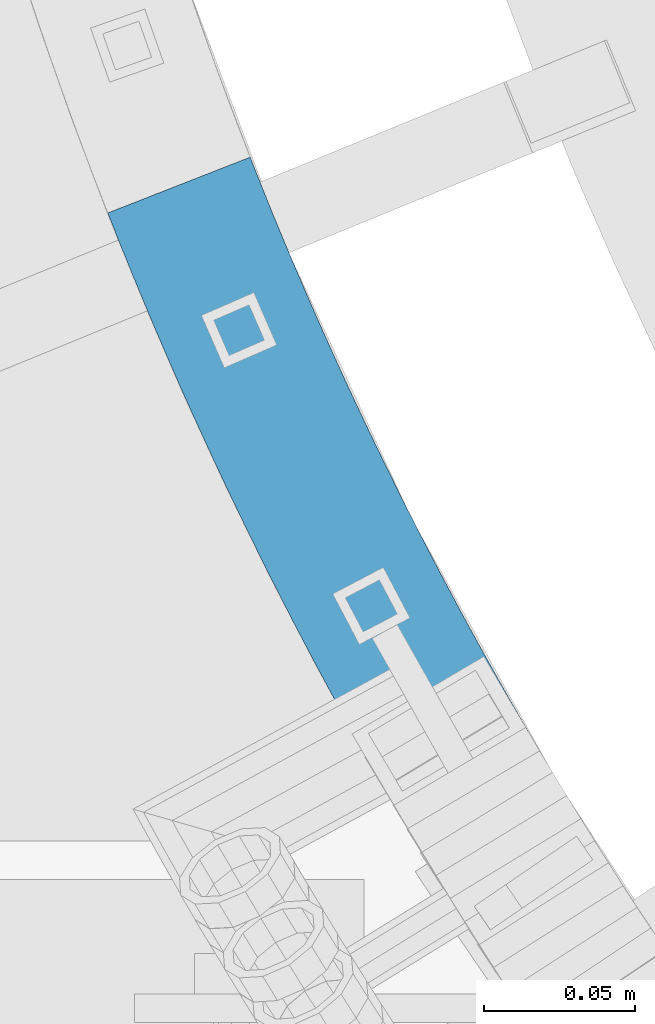
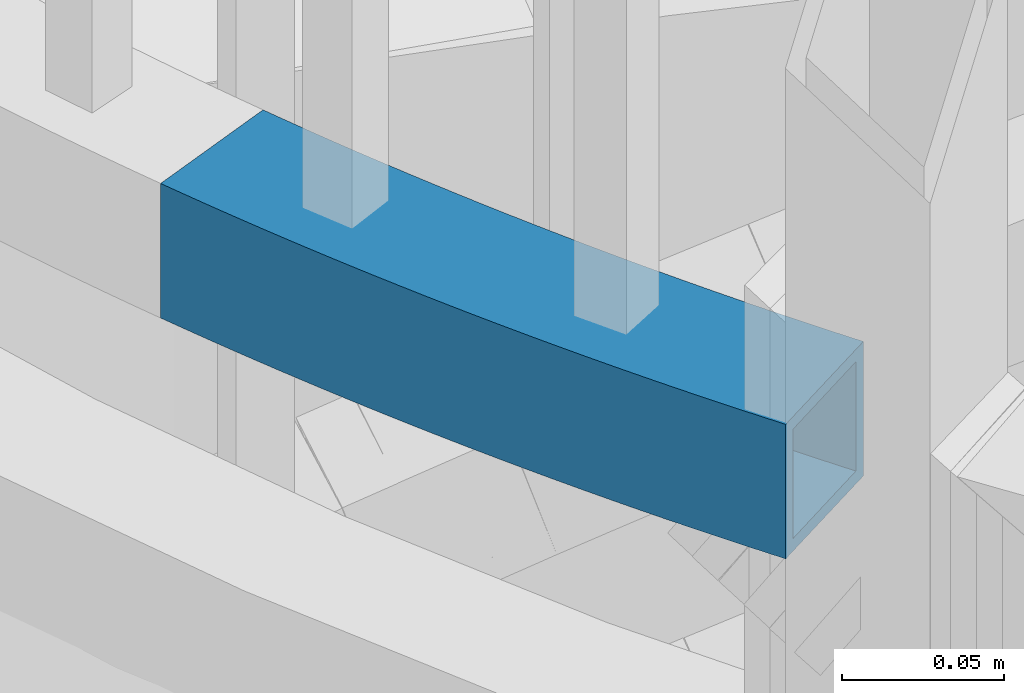
# One storey, part 473 of 975: 1 beam.
"""IFC2X3 building model written with IfcOpenShell, lengths in millimetres."""

from ifc_helpers import new_model, si_unit, frame, origin_with_axes, place, context, subcontext, project, spatial, faceted_brep, material, type_object, element, save


model = new_model("IFC2X3")

# Units and contexts
model_context = context("Model", 3, precision=1e-05, world=origin_with_axes())
body_context = subcontext(model_context, "Body", "Model", "MODEL_VIEW")
ifc_project = project(units=[si_unit("LENGTHUNIT", "METRE", prefix="MILLI"), si_unit("AREAUNIT", "SQUARE_METRE"), si_unit("VOLUMEUNIT", "CUBIC_METRE"), si_unit("MASSUNIT", "GRAM", prefix="KILO"), si_unit("TIMEUNIT", "SECOND"), si_unit("PLANEANGLEUNIT", "RADIAN"), si_unit("SOLIDANGLEUNIT", "STERADIAN"), si_unit("THERMODYNAMICTEMPERATUREUNIT", "DEGREE_CELSIUS"), si_unit("LUMINOUSINTENSITYUNIT", "LUMEN")], contexts=[model_context])

# Site, building, storey
site_placement = place(None, origin_with_axes())
site = spatial("IfcSite", under=ifc_project, at=site_placement, CompositionType="ELEMENT")
building_placement = place(site_placement, origin_with_axes())
building = spatial("IfcBuilding", under=site, at=building_placement, Name="Undefined", CompositionType="ELEMENT")
storey_placement = place(building_placement, origin_with_axes())
storey = spatial("IfcBuildingStorey", under=building, at=storey_placement, Name="Undefined", CompositionType="ELEMENT", Elevation=0.0)

# Beam
ifc_material = material()
beam_type = type_object("IfcBeamType", Name="HSS2X2X.188_TUBES", PredefinedType="NOTDEFINED")
beam_placement = place(storey_placement, frame((33547.4569280127, 2667.02838416945, 4254.5), z_axis=(0.0, 0.0, 1.0), x_axis=(-0.447935289860979, 0.894065979722504, 0.0)))
element("IfcBeam", 1, at=beam_placement, inside=storey, type_object=beam_type, material=ifc_material, Name="HANDRAIL", ObjectType="HSS2X2X.188_TUBES", context=body_context, shape_type="Brep", body=[
    faceted_brep([(23.9062195662409, 27.4404749350106, -25.3999999999996), (23.9062195662409, 27.4404749350106, 25.3999999999996), (28.2785710531207, 27.7508996670804, 25.3999999999996), (28.2785710531207, 27.7508996670804, -25.3999999999996), (32.6518584018995, 28.0478488278641, 25.3999999999996), (32.6518584018995, 28.0478488278641, -25.3999999999996), (37.0260400810184, 28.3313195973642, 25.3999999999996), (37.0260400810184, 28.3313195973642, -25.3999999999996), (41.4010745504183, 28.6013092835383, 25.3999999999996), (41.4010745504183, 28.6013092835383, -25.3999999999996), (45.7769202619493, 28.8578153224043, 25.3999999999996), (45.7769202619493, 28.8578153224043, -25.3999999999996), (50.1535356597506, 29.1008352780118, 25.3999999999996), (50.1535356597506, 29.1008352780118, -25.3999999999996), (54.5308791806547, 29.3303668424778, 25.3999999999996), (54.5308791806547, 29.3303668424778, -25.3999999999996), (58.9089092545819, 29.5464078360383, 25.3999999999996), (58.9089092545819, 29.5464078360383, -25.3999999999996), (63.287584304926, 29.748956207015, 25.3999999999996), (63.287584304926, 29.748956207015, -25.3999999999996), (67.6668627489616, 29.9380100318813, 25.3999999999996), (67.6668627489616, 29.9380100318813, -25.3999999999996), (72.0467029982283, 30.1135675152582, 25.3999999999996), (72.0467029982283, 30.1135675152582, -25.3999999999996), (76.4270634589393, 30.2756269899437, 25.3999999999996), (76.4270634589393, 30.2756269899437, -25.3999999999996), (80.8079025323568, 30.4241869169091, 25.3999999999996), (80.8079025323568, 30.4241869169091, -25.3999999999996), (85.1891786152064, 30.5592458853425, 25.3999999999996), (85.1891786152064, 30.5592458853425, -25.3999999999996), (89.5708501000554, 30.6808026126237, 25.3999999999996), (89.5708501000554, 30.6808026126237, -25.3999999999996), (93.9528753757222, 30.7888559443927, 25.3999999999996), (93.9528753757222, 30.7888559443927, -25.3999999999996), (98.3352128276638, 30.8834048544813, 25.3999999999996), (98.3352128276638, 30.8834048544813, -25.3999999999996), (102.717820838372, 30.9644484450073, 25.3999999999996), (102.717820838372, 30.9644484450073, -25.3999999999996), (107.100657787771, 31.0319859463198, 25.3999999999996), (107.100657787771, 31.0319859463198, -25.3999999999996), (111.483682053604, 31.0860167170431, 25.3999999999996), (111.483682053604, 31.0860167170431, -25.3999999999996), (115.866852011846, 31.1265402440658, 25.3999999999996), (115.866852011846, 31.1265402440658, -25.3999999999996), (120.250126037085, 31.1535561425553, 25.3999999999996), (120.250126037085, 31.1535561425553, -25.3999999999996), (124.633462502912, 31.1670641559431, 25.3999999999996), (124.633462502912, 31.1670641559431, -25.3999999999996), (129.016819782339, 31.1670641559576, 25.3999999999996), (129.016819782339, 31.1670641559576, -25.3999999999996), (133.400156248168, 31.1535561425808, 25.3999999999996), (133.400156248168, 31.1535561425808, -25.3999999999996), (137.783430273403, 31.1265402441131, 25.3999999999996), (137.783430273403, 31.1265402441131, -25.3999999999996), (142.166600231645, 31.0860167171049, 25.3999999999996), (142.166600231645, 31.0860167171049, -25.3999999999996), (146.549624497482, 31.0319859464034, 25.3999999999996), (146.549624497482, 31.0319859464034, -25.3999999999996), (150.932461446881, 30.9644484451055, 25.3999999999996), (150.932461446881, 30.9644484451055, -25.3999999999996), (155.315069457589, 30.8834048545978, 25.3999999999996), (155.315069457589, 30.8834048545978, -25.3999999999996), (159.69740690953, 30.7888559445273, 25.3999999999996), (159.69740690953, 30.7888559445273, -25.3999999999996), (164.079432185195, 30.6808026127837, 25.3999999999996), (164.079432185195, 30.6808026127837, -25.3999999999996), (168.461103670044, 30.5592458855135, 25.3999999999996), (168.461103670044, 30.5592458855135, -25.3999999999996), (172.842379752894, 30.4241869171019, 25.3999999999996), (172.842379752894, 30.4241869171019, -25.3999999999996), (177.223218826313, 30.2756269901547, 25.3999999999996), (177.223218826313, 30.2756269901547, -25.3999999999996), (181.603579287021, 30.1135675154837, 25.3999999999996), (181.603579287021, 30.1135675154837, -25.3999999999996), (185.983419536291, 29.938010032125, 25.3999999999996), (185.983419536291, 29.938010032125, -25.3999999999996), (190.362697980328, 29.7489562072806, 25.3999999999996), (190.362697980328, 29.7489562072806, -25.3999999999996), (194.741373030673, 29.546407836322, 25.3999999999996), (194.741373030673, 29.546407836322, -25.3999999999996), (199.119403104596, 29.330366842787, 25.3999999999996), (199.119403104596, 29.330366842787, -25.3999999999996), (203.4967466255, 29.1008352783319, 25.3999999999996), (203.4967466255, 29.1008352783319, -25.3999999999996), (207.8733620233, 28.8578153227427, 25.3999999999996), (207.8733620233, 28.8578153227427, -25.3999999999996), (212.249207734832, 28.6013092838984, 25.3999999999996), (212.249207734832, 28.6013092838984, -25.3999999999996), (216.624242204234, 28.3313195977425, 25.3999999999996), (216.624242204234, 28.3313195977425, -25.3999999999996), (220.998423883351, 28.047848828257, 25.3999999999996), (220.998423883351, 28.047848828257, -25.3999999999996), (225.371711232134, 27.7508996674915, 25.3999999999996), (225.371711232134, 27.7508996674915, -25.3999999999996), (229.744062719008, 27.4404749354362, 25.3999999999996), (229.744062719008, 27.4404749354362, -25.3999999999996), (234.115436821316, 27.1165775801164, 25.3999999999996), (234.115436821316, 27.1165775801164, -25.3999999999996), (238.485792025651, 26.7792106774468, 25.3999999999996), (238.485792025651, 26.7792106774468, -25.3999999999996), (242.855086828302, 26.4283774312898, 25.3999999999996), (242.855086828302, 26.4283774312898, -25.3999999999996), (247.223279735621, 26.0640811733865, 25.3999999999996), (247.223279735621, 26.0640811733865, -25.3999999999996), (251.590329264425, 25.6863253633237, 25.3999999999996), (251.590329264425, 25.6863253633237, -25.3999999999996), (247.134429688649, -24.9178736617832, 25.3999999999996), (247.134429688649, -24.9178736617832, -25.3999999999996), (251.344370628121, -25.2951135874791, -25.3999999999996), (251.344370628121, -25.2951135874791, 25.3999999999996), (242.923346214446, -24.5536091306494, 25.3999999999996), (242.923346214446, -24.5536091306494, -25.3999999999996), (238.711160196672, -24.2023234533845, 25.3999999999996), (238.711160196672, -24.2023234533845, -25.3999999999996), (234.497911636974, -23.8640199660222, 25.3999999999996), (234.497911636974, -23.8640199660222, -25.3999999999996), (230.283640547077, -23.5387018813053, 25.3999999999996), (230.283640547077, -23.5387018813053, -25.3999999999996), (226.068386948427, -23.2263722886673, 25.3999999999996), (226.068386948427, -23.2263722886673, -25.3999999999996), (221.852190871796, -22.927034154196, 25.3999999999996), (221.852190871796, -22.927034154196, -25.3999999999996), (217.635092356897, -22.6406903205971, 25.3999999999996), (217.635092356897, -22.6406903205971, -25.3999999999996), (213.417131452035, -22.3673435071651, 25.3999999999996), (213.417131452035, -22.3673435071651, -25.3999999999996), (209.198348213684, -22.1069963098016, 25.3999999999996), (209.198348213684, -22.1069963098016, -25.3999999999996), (204.978782706135, -21.8596512009135, 25.3999999999996), (204.978782706135, -21.8596512009135, -25.3999999999996), (200.758475001116, -21.6253105294527, 25.3999999999996), (200.758475001116, -21.6253105294527, -25.3999999999996), (196.537465177385, -21.4039765208763, 25.3999999999996), (196.537465177385, -21.4039765208763, -25.3999999999996), (192.315793320387, -21.195651277103, 25.3999999999996), (192.315793320387, -21.195651277103, -25.3999999999996), (188.093499521841, -21.0003367765385, 25.3999999999996), (188.093499521841, -21.0003367765385, -25.3999999999996), (183.870623879375, -20.8180348740061, 25.3999999999996), (183.870623879375, -20.8180348740061, -25.3999999999996), (179.647206496153, -20.6487473007692, 25.3999999999996), (179.647206496153, -20.6487473007692, -25.3999999999996), (175.423287480466, -20.4924756644832, 25.3999999999996), (175.423287480466, -20.4924756644832, -25.3999999999996), (171.198906945387, -20.3492214492107, 25.3999999999996), (171.198906945387, -20.3492214492107, -25.3999999999996), (166.974105008354, -20.2189860153849, 25.3999999999996), (166.974105008354, -20.2189860153849, -25.3999999999996), (162.748921790821, -20.1017705998056, 25.3999999999996), (162.748921790821, -20.1017705998056, -25.3999999999996), (158.523397417857, -19.9975763156217, 25.3999999999996), (158.523397417857, -19.9975763156217, -25.3999999999996), (154.297572017769, -19.9064041523379, 25.3999999999996), (154.297572017769, -19.9064041523379, -25.3999999999996), (150.071485721728, -19.828254975786, 25.3999999999996), (150.071485721728, -19.828254975786, -25.3999999999996), (145.845178663381, -19.7631295281026, 25.3999999999996), (145.845178663381, -19.7631295281026, -25.3999999999996), (141.61869097847, -19.7110284277733, 25.3999999999996), (141.61869097847, -19.7110284277733, -25.3999999999996), (137.392062804451, -19.6719521695886, 25.3999999999996), (137.392062804451, -19.6719521695886, -25.3999999999996), (133.165334280113, -19.6459011246407, 25.3999999999996), (133.165334280113, -19.6459011246407, -25.3999999999996), (128.938545545208, -19.6328755403156, 25.3999999999996), (128.938545545208, -19.6328755403156, -25.3999999999996), (124.71173674005, -19.6328755403265, 25.3999999999996), (124.71173674005, -19.6328755403265, -25.3999999999996), (120.484948005142, -19.6459011246661, 25.3999999999996), (120.484948005142, -19.6459011246661, -25.3999999999996), (116.258219480806, -19.6719521696396, 25.3999999999996), (116.258219480806, -19.6719521696396, -25.3999999999996), (112.031591306786, -19.7110284278424, 25.3999999999996), (112.031591306786, -19.7110284278424, -25.3999999999996), (107.805103621871, -19.7631295281826, 25.3999999999996), (107.805103621871, -19.7631295281826, -25.3999999999996), (103.578796563525, -19.8282549758769, 25.3999999999996), (103.578796563525, -19.8282549758769, -25.3999999999996), (99.3527102674871, -19.9064041524507, 25.3999999999996), (99.3527102674871, -19.9064041524507, -25.3999999999996), (95.1268848674008, -19.9975763157527, 25.3999999999996), (95.1268848674008, -19.9975763157527, -25.3999999999996), (90.9013604944339, -20.1017705999548, 25.3999999999996), (90.9013604944339, -20.1017705999548, -25.3999999999996), (86.6761772769023, -20.2189860155486, 25.3999999999996), (86.6761772769023, -20.2189860155486, -25.3999999999996), (82.4513753398696, -20.3492214493963, 25.3999999999996), (82.4513753398696, -20.3492214493963, -25.3999999999996), (78.226994804787, -20.4924756646906, 25.3999999999996), (78.226994804787, -20.4924756646906, -25.3999999999996), (74.0030757891036, -20.6487473009911, 25.3999999999996), (74.0030757891036, -20.6487473009911, -25.3999999999996), (69.7796584058797, -20.8180348742462, 25.3999999999996), (69.7796584058797, -20.8180348742462, -25.3999999999996), (65.556782763415, -21.0003367767968, 25.3999999999996), (65.556782763415, -21.0003367767968, -25.3999999999996), (61.3344889648706, -21.1956512773759, 25.3999999999996), (61.3344889648706, -21.1956512773759, -25.3999999999996), (57.1128171078708, -21.4039765211674, 25.3999999999996), (57.1128171078708, -21.4039765211674, -25.3999999999996), (52.8918072841407, -21.6253105297619, 25.3999999999996), (52.8918072841407, -21.6253105297619, -25.3999999999996), (48.6714995791208, -21.8596512012336, 25.3999999999996), (48.6714995791208, -21.8596512012336, -25.3999999999996), (44.4519340715724, -22.1069963101436, 25.3999999999996), (44.4519340715724, -22.1069963101436, -25.3999999999996), (40.2331508332209, -22.3673435075289, 25.3999999999996), (40.2331508332209, -22.3673435075289, -25.3999999999996), (36.0151899283574, -22.6406903209718, 25.3999999999996), (36.0151899283574, -22.6406903209718, -25.3999999999996), (31.7980914134623, -22.9270341545925, 25.3999999999996), (31.7980914134623, -22.9270341545925, -25.3999999999996), (27.5818953368289, -23.2263722890821, 25.3999999999996), (27.5818953368289, -23.2263722890821, -25.3999999999996), (255.956193942395, 25.2951135885232, -25.3999999999996), (23.0098913682887, 27.3740614169692, -25.3999999999996), (23.0098913682887, 27.3740614169692, 25.3999999999996), (255.956193942395, 25.2951135885232, 25.3999999999996), (24.2508141697344, 22.6904580077571, 20.6374999999998), (24.2508141697344, 22.6904580077571, -20.6374999999998), (28.6085260869022, 22.9998433712935, -20.6374999999998), (28.6085260869022, 22.9998433712935, 20.6374999999998), (32.9671707325051, 23.2957982826629, -20.6374999999998), (32.9671707325051, 23.2957982826629, 20.6374999999998), (37.3267067140368, 23.5783199312827, -20.6374999999998), (37.3267067140368, 23.5783199312827, 20.6374999999998), (41.6870926305273, 23.8474056341292, -20.6374999999998), (41.6870926305273, 23.8474056341292, 20.6374999999998), (46.0482870729338, 24.1030528358169, -20.6374999999998), (46.0482870729338, 24.1030528358169, 20.6374999999998), (50.4102486245374, 24.3452591085334, -20.6374999999998), (50.4102486245374, 24.3452591085334, 20.6374999999998), (54.7729358613324, 24.5740221521446, -20.6374999999998), (54.7729358613324, 24.5740221521446, 20.6374999999998), (59.136307352419, 24.7893397941552, -20.6374999999998), (59.136307352419, 24.7893397941552, 20.6374999999998), (63.5003216604091, 24.9912099897847, -20.6374999999998), (63.5003216604091, 24.9912099897847, 20.6374999999998), (67.8649373417975, 25.1796308219346, -20.6374999999998), (67.8649373417975, 25.1796308219346, 20.6374999999998), (72.2301129473726, 25.3546005012358, -20.6374999999998), (72.2301129473726, 25.3546005012358, 20.6374999999998), (76.5958070226116, 25.5161173660672, -20.6374999999998), (76.5958070226116, 25.5161173660672, 20.6374999999998), (80.9619781080637, 25.6641798825694, -20.6374999999998), (80.9619781080637, 25.6641798825694, 20.6374999999998), (85.3285847397401, 25.798786644631, -20.6374999999998), (85.3285847397401, 25.798786644631, 20.6374999999998), (89.6955854495282, 25.9199363739499, -20.6374999999998), (89.6955854495282, 25.9199363739499, 20.6374999999998), (94.0629387655663, 26.0276279200007, -20.6374999999998), (94.0629387655663, 26.0276279200007, 20.6374999999998), (98.4306032126442, 26.1218602600784, -20.6374999999998), (98.4306032126442, 26.1218602600784, 20.6374999999998), (102.798537312605, 26.2026324992985, -20.6374999999998), (102.798537312605, 26.2026324992985, 20.6374999999998), (107.166699584717, 26.2699438705858, -20.6374999999998), (107.166699584717, 26.2699438705858, 20.6374999999998), (111.535048546089, 26.3237937347112, -20.6374999999998), (111.535048546089, 26.3237937347112, 20.6374999999998), (115.903542712063, 26.3641815802839, -20.6374999999998), (115.903542712063, 26.3641815802839, 20.6374999999998), (120.272140596593, 26.3911070237555, -20.6374999999998), (120.272140596593, 26.3911070237555, 20.6374999999998), (124.640800712645, 26.4045698094196, -20.6374999999998), (124.640800712645, 26.4045698094196, 20.6374999999998), (129.009481572604, 26.4045698094269, -20.6374999999998), (129.009481572604, 26.4045698094269, 20.6374999999998), (133.378141688663, 26.3911070237846, -20.6374999999998), (133.378141688663, 26.3911070237846, 20.6374999999998), (137.746739573187, 26.3641815803276, -20.6374999999998), (137.746739573187, 26.3641815803276, 20.6374999999998), (142.115233739161, 26.3237937347731, -20.6374999999998), (142.115233739161, 26.3237937347731, 20.6374999999998), (146.483582700535, 26.2699438706695, -20.6374999999998), (146.483582700535, 26.2699438706695, 20.6374999999998), (150.851744972646, 26.2026324993967, -20.6374999999998), (150.851744972646, 26.2026324993967, 20.6374999999998), (155.219679072605, 26.1218602602021, -20.6374999999998), (155.219679072605, 26.1218602602021, 20.6374999999998), (159.587343519683, 26.0276279201316, -20.6374999999998), (159.587343519683, 26.0276279201316, 20.6374999999998), (163.954696835724, 25.9199363741027, -20.6374999999998), (163.954696835724, 25.9199363741027, 20.6374999999998), (168.321697545513, 25.798786644802, -20.6374999999998), (168.321697545513, 25.798786644802, 20.6374999999998), (172.688304177189, 25.6641798827586, -20.6374999999998), (172.688304177189, 25.6641798827586, 20.6374999999998), (177.054475262637, 25.5161173662782, -20.6374999999998), (177.054475262637, 25.5161173662782, 20.6374999999998), (181.420169337878, 25.3546005014614, -20.6374999999998), (181.420169337878, 25.3546005014614, 20.6374999999998), (185.785344943455, 25.1796308221747, -20.6374999999998), (185.785344943455, 25.1796308221747, 20.6374999999998), (190.149960624845, 24.9912099900466, -20.6374999999998), (190.149960624845, 24.9912099900466, 20.6374999999998), (194.513974932832, 24.7893397944354, -20.6374999999998), (194.513974932832, 24.7893397944354, 20.6374999999998), (198.877346423922, 24.5740221524429, -20.6374999999998), (198.877346423922, 24.5740221524429, 20.6374999999998), (203.240033660715, 24.3452591088535, -20.6374999999998), (203.240033660715, 24.3452591088535, 20.6374999999998), (207.601995212317, 24.1030528361553, -20.6374999999998), (207.601995212317, 24.1030528361553, 20.6374999999998), (211.963189654723, 23.8474056344858, -20.6374999999998), (211.963189654723, 23.8474056344858, 20.6374999999998), (216.323575571212, 23.5783199316502, -20.6374999999998), (216.323575571212, 23.5783199316502, 20.6374999999998), (220.683111552746, 23.2957982830558, -20.6374999999998), (220.683111552746, 23.2957982830558, 20.6374999999998), (225.04175619835, 22.9998433717083, -20.6374999999998), (225.04175619835, 22.9998433717083, 20.6374999999998), (229.399468115516, 22.6904580081791, -20.6374999999998), (229.399468115516, 22.6904580081791, 20.6374999999998), (233.756205920603, 22.3676451306019, -20.6374999999998), (233.756205920603, 22.3676451306019, 20.6374999999998), (238.11192823921, 22.0314078046213, -20.6374999999998), (238.11192823921, 22.0314078046213, 20.6374999999998), (242.466593706587, 21.6817492233531, -20.6374999999998), (242.466593706587, 21.6817492233531, 20.6374999999998), (246.820160968009, 21.3186727073808, -20.6374999999998), (246.820160968009, 21.3186727073808, 20.6374999999998), (251.172588679197, 20.942181704726, -20.6374999999998), (251.172588679197, 20.942181704726, 20.6374999999998), (255.523835506681, 20.5522797907688, -20.6374999999998), (255.523835506681, 20.5522797907688, 20.6374999999998), (251.776729063833, -20.552279789732, 20.6374999999998), (251.776729063833, -20.552279789732, -20.6374999999998), (247.552170273881, -20.1737300031782, -20.6374999999998), (247.552170273881, -20.1737300031782, 20.6374999999998), (243.326464982052, -19.8082006646509, -20.6374999999998), (243.326464982052, -19.8082006646509, 20.6374999999998), (239.099653318386, -19.4556952454477, -20.6374999999998), (239.099653318386, -19.4556952454477, 20.6374999999998), (234.871775423409, -19.1162170932002, -20.6374999999998), (234.871775423409, -19.1162170932002, 20.6374999999998), (230.642871447788, -18.7897694317944, -20.6374999999998), (230.642871447788, -18.7897694317944, 20.6374999999998), (226.412981551919, -18.4763553614102, -20.6374999999998), (226.412981551919, -18.4763553614102, 20.6374999999998), (222.182145905574, -18.1759778584164, -20.6374999999998), (222.182145905574, -18.1759778584164, 20.6374999999998), (217.950404687504, -17.8886397753849, -20.6374999999998), (217.950404687504, -17.8886397753849, 20.6374999999998), (213.717798085054, -17.6143438410836, -20.6374999999998), (213.717798085054, -17.6143438410836, 20.6374999999998), (209.484366293791, -17.3530926603926, -20.6374999999998), (209.484366293791, -17.3530926603926, 20.6374999999998), (205.25014951712, -17.1048887143224, -20.6374999999998), (205.25014951712, -17.1048887143224, 20.6374999999998), (201.015187965899, -16.8697343599742, -20.6374999999998), (201.015187965899, -16.8697343599742, 20.6374999999998), (196.77952185806, -16.6476318305322, -20.6374999999998), (196.77952185806, -16.6476318305322, 20.6374999999998), (192.543191418225, -16.4385832352273, -20.6374999999998), (192.543191418225, -16.4385832352273, 20.6374999999998), (188.306236877324, -16.2425905593045, -20.6374999999998), (188.306236877324, -16.2425905593045, 20.6374999999998), (184.068698472214, -16.0596556640558, -20.6374999999998), (184.068698472214, -16.0596556640558, 20.6374999999998), (179.830616445295, -15.8897802867468, -20.6374999999998), (179.830616445295, -15.8897802867468, 20.6374999999998), (175.592031044143, -15.7329660406103, -20.6374999999998), (175.592031044143, -15.7329660406103, 20.6374999999998), (171.35298252109, -15.5892144148675, -20.6374999999998), (171.35298252109, -15.5892144148675, 20.6374999999998), (167.113511132889, -15.4585267746734, -20.6374999999998), (167.113511132889, -15.4585267746734, 20.6374999999998), (162.873657140293, -15.3409043611246, -20.6374999999998), (162.873657140293, -15.3409043611246, 20.6374999999998), (158.633460807701, -15.2363482912369, -20.6374999999998), (158.633460807701, -15.2363482912369, 20.6374999999998), (154.392962402751, -15.1448595579386, -20.6374999999998), (154.392962402751, -15.1448595579386, 20.6374999999998), (150.152202195963, -15.0664390300735, -20.6374999999998), (150.152202195963, -15.0664390300735, 20.6374999999998), (145.91122046033, -15.001087452365, -20.6374999999998), (145.91122046033, -15.001087452365, 20.6374999999998), (141.670057470958, -14.9488054454414, -20.6374999999998), (141.670057470958, -14.9488054454414, 20.6374999999998), (137.428753504664, -14.9095935058067, -20.6374999999998), (137.428753504664, -14.9095935058067, 20.6374999999998), (133.18734883962, -14.8834520058335, -20.6374999999998), (133.18734883962, -14.8834520058335, 20.6374999999998), (128.945883754939, -14.8703811937921, -20.6374999999998), (128.945883754939, -14.8703811937921, 20.6374999999998), (124.704398530317, -14.8703811937994, -20.6374999999998), (124.704398530317, -14.8703811937994, 20.6374999999998), (120.462933445637, -14.8834520058626, -20.6374999999998), (120.462933445637, -14.8834520058626, 20.6374999999998), (116.22152878059, -14.9095935058504, -20.6374999999998), (116.22152878059, -14.9095935058504, 20.6374999999998), (111.980224814301, -14.9488054455069, -20.6374999999998), (111.980224814301, -14.9488054455069, 20.6374999999998), (107.739061824928, -15.0010874524414, -20.6374999999998), (107.739061824928, -15.0010874524414, 20.6374999999998), (103.498080089292, -15.0664390301681, -20.6374999999998), (103.498080089292, -15.0664390301681, 20.6374999999998), (99.2573198825012, -15.144859558055, -20.6374999999998), (99.2573198825012, -15.144859558055, 20.6374999999998), (95.0168214775549, -15.2363482913715, -20.6374999999998), (95.0168214775549, -15.2363482913715, 20.6374999999998), (90.776625144963, -15.3409043612701, -20.6374999999998), (90.776625144963, -15.3409043612701, 20.6374999999998), (86.5367711523668, -15.4585267748444, -20.6374999999998), (86.5367711523668, -15.4585267748444, 20.6374999999998), (82.2972997641664, -15.5892144150494, -20.6374999999998), (82.2972997641664, -15.5892144150494, 20.6374999999998), (78.0582512411129, -15.7329660408141, -20.6374999999998), (78.0582512411129, -15.7329660408141, 20.6374999999998), (73.8196658399575, -15.8897802869687, -20.6374999999998), (73.8196658399575, -15.8897802869687, 20.6374999999998), (69.5815838130438, -16.0596556642959, -20.6374999999998), (69.5815838130438, -16.0596556642959, 20.6374999999998), (65.3440454079318, -16.2425905595628, -20.6374999999998), (65.3440454079318, -16.2425905595628, 20.6374999999998), (61.1070908670299, -16.4385832355001, -20.6374999999998), (61.1070908670299, -16.4385832355001, 20.6374999999998), (56.8707604271949, -16.6476318308196, -20.6374999999998), (56.8707604271949, -16.6476318308196, 20.6374999999998), (52.6350943193556, -16.8697343602798, -20.6374999999998), (52.6350943193556, -16.8697343602798, 20.6374999999998), (48.4001327681362, -17.1048887146426, -20.6374999999998), (48.4001327681362, -17.1048887146426, 20.6374999999998), (44.1659159914634, -17.3530926607345, -20.6374999999998), (44.1659159914634, -17.3530926607345, 20.6374999999998), (39.9324842002006, -17.6143438414474, -20.6374999999998), (39.9324842002006, -17.6143438414474, 20.6374999999998), (35.6998775977518, -17.8886397757669, -20.6374999999998), (35.6998775977518, -17.8886397757669, 20.6374999999998), (31.4681363796808, -18.1759778588093, -20.6374999999998), (31.4681363796808, -18.1759778588093, 20.6374999999998), (27.2373007333354, -18.4763553618213, 20.6374999999998), (23.4423115260724, 22.6305519320158, 20.6374999999998), (23.4423115260724, 22.6305519320158, -20.6374999999998), (27.2373007333354, -18.4763553618213, -20.6374999999998)], [[[0, 1, 2, 3]], [[3, 2, 4, 5]], [[5, 4, 6, 7]], [[7, 6, 8, 9]], [[9, 8, 10, 11]], [[11, 10, 12, 13]], [[13, 12, 14, 15]], [[15, 14, 16, 17]], [[17, 16, 18, 19]], [[19, 18, 20, 21]], [[21, 20, 22, 23]], [[23, 22, 24, 25]], [[25, 24, 26, 27]], [[27, 26, 28, 29]], [[29, 28, 30, 31]], [[31, 30, 32, 33]], [[33, 32, 34, 35]], [[35, 34, 36, 37]], [[37, 36, 38, 39]], [[39, 38, 40, 41]], [[41, 40, 42, 43]], [[43, 42, 44, 45]], [[45, 44, 46, 47]], [[47, 46, 48, 49]], [[49, 48, 50, 51]], [[51, 50, 52, 53]], [[53, 52, 54, 55]], [[55, 54, 56, 57]], [[57, 56, 58, 59]], [[59, 58, 60, 61]], [[61, 60, 62, 63]], [[63, 62, 64, 65]], [[65, 64, 66, 67]], [[67, 66, 68, 69]], [[69, 68, 70, 71]], [[71, 70, 72, 73]], [[73, 72, 74, 75]], [[75, 74, 76, 77]], [[77, 76, 78, 79]], [[79, 78, 80, 81]], [[81, 80, 82, 83]], [[83, 82, 84, 85]], [[85, 84, 86, 87]], [[87, 86, 88, 89]], [[89, 88, 90, 91]], [[91, 90, 92, 93]], [[93, 92, 94, 95]], [[95, 94, 96, 97]], [[97, 96, 98, 99]], [[99, 98, 100, 101]], [[101, 100, 102, 103]], [[103, 102, 104, 105]], [[106, 107, 108, 109]], [[110, 111, 107, 106]], [[112, 113, 111, 110]], [[114, 115, 113, 112]], [[116, 117, 115, 114]], [[118, 119, 117, 116]], [[120, 121, 119, 118]], [[122, 123, 121, 120]], [[124, 125, 123, 122]], [[126, 127, 125, 124]], [[128, 129, 127, 126]], [[130, 131, 129, 128]], [[132, 133, 131, 130]], [[134, 135, 133, 132]], [[136, 137, 135, 134]], [[138, 139, 137, 136]], [[140, 141, 139, 138]], [[142, 143, 141, 140]], [[144, 145, 143, 142]], [[146, 147, 145, 144]], [[148, 149, 147, 146]], [[150, 151, 149, 148]], [[152, 153, 151, 150]], [[154, 155, 153, 152]], [[156, 157, 155, 154]], [[158, 159, 157, 156]], [[160, 161, 159, 158]], [[162, 163, 161, 160]], [[164, 165, 163, 162]], [[166, 167, 165, 164]], [[168, 169, 167, 166]], [[170, 171, 169, 168]], [[172, 173, 171, 170]], [[174, 175, 173, 172]], [[176, 177, 175, 174]], [[178, 179, 177, 176]], [[180, 181, 179, 178]], [[182, 183, 181, 180]], [[184, 185, 183, 182]], [[186, 187, 185, 184]], [[188, 189, 187, 186]], [[190, 191, 189, 188]], [[192, 193, 191, 190]], [[194, 195, 193, 192]], [[196, 197, 195, 194]], [[198, 199, 197, 196]], [[200, 201, 199, 198]], [[202, 203, 201, 200]], [[204, 205, 203, 202]], [[206, 207, 205, 204]], [[208, 209, 207, 206]], [[210, 211, 209, 208]], [[211, 210, 212, 213]], [[0, 3, 5, 7, 9, 11, 13, 15, 17, 19, 21, 23, 25, 27, 29, 31, 33, 35, 37, 39, 41, 43, 45, 47, 49, 51, 53, 55, 57, 59, 61, 63, 65, 67, 69, 71, 73, 75, 77, 79, 81, 83, 85, 87, 89, 91, 93, 95, 97, 99, 101, 103, 105, 214, 108, 107, 111, 113, 115, 117, 119, 121, 123, 125, 127, 129, 131, 133, 135, 137, 139, 141, 143, 145, 147, 149, 151, 153, 155, 157, 159, 161, 163, 165, 167, 169, 171, 173, 175, 177, 179, 181, 183, 185, 187, 189, 191, 193, 195, 197, 199, 201, 203, 205, 207, 209, 211, 213, 215]], [[1, 0, 215, 216]], [[210, 208, 206, 204, 202, 200, 198, 196, 194, 192, 190, 188, 186, 184, 182, 180, 178, 176, 174, 172, 170, 168, 166, 164, 162, 160, 158, 156, 154, 152, 150, 148, 146, 144, 142, 140, 138, 136, 134, 132, 130, 128, 126, 124, 122, 120, 118, 116, 114, 112, 110, 106, 109, 217, 104, 102, 100, 98, 96, 94, 92, 90, 88, 86, 84, 82, 80, 78, 76, 74, 72, 70, 68, 66, 64, 62, 60, 58, 56, 54, 52, 50, 48, 46, 44, 42, 40, 38, 36, 34, 32, 30, 28, 26, 24, 22, 20, 18, 16, 14, 12, 10, 8, 6, 4, 2, 1, 216, 212]], [[105, 104, 217, 214]], [[218, 219, 220, 221]], [[221, 220, 222, 223]], [[223, 222, 224, 225]], [[225, 224, 226, 227]], [[227, 226, 228, 229]], [[229, 228, 230, 231]], [[231, 230, 232, 233]], [[233, 232, 234, 235]], [[235, 234, 236, 237]], [[237, 236, 238, 239]], [[239, 238, 240, 241]], [[241, 240, 242, 243]], [[243, 242, 244, 245]], [[245, 244, 246, 247]], [[247, 246, 248, 249]], [[249, 248, 250, 251]], [[251, 250, 252, 253]], [[253, 252, 254, 255]], [[255, 254, 256, 257]], [[257, 256, 258, 259]], [[259, 258, 260, 261]], [[261, 260, 262, 263]], [[263, 262, 264, 265]], [[265, 264, 266, 267]], [[267, 266, 268, 269]], [[269, 268, 270, 271]], [[271, 270, 272, 273]], [[273, 272, 274, 275]], [[275, 274, 276, 277]], [[277, 276, 278, 279]], [[279, 278, 280, 281]], [[281, 280, 282, 283]], [[283, 282, 284, 285]], [[285, 284, 286, 287]], [[287, 286, 288, 289]], [[289, 288, 290, 291]], [[291, 290, 292, 293]], [[293, 292, 294, 295]], [[295, 294, 296, 297]], [[297, 296, 298, 299]], [[299, 298, 300, 301]], [[301, 300, 302, 303]], [[303, 302, 304, 305]], [[305, 304, 306, 307]], [[307, 306, 308, 309]], [[309, 308, 310, 311]], [[311, 310, 312, 313]], [[313, 312, 314, 315]], [[315, 314, 316, 317]], [[317, 316, 318, 319]], [[319, 318, 320, 321]], [[321, 320, 322, 323]], [[323, 322, 324, 325]], [[109, 108, 214, 217], [326, 325, 324, 327]], [[328, 329, 326, 327]], [[330, 331, 329, 328]], [[332, 333, 331, 330]], [[334, 335, 333, 332]], [[336, 337, 335, 334]], [[338, 339, 337, 336]], [[340, 341, 339, 338]], [[342, 343, 341, 340]], [[344, 345, 343, 342]], [[346, 347, 345, 344]], [[348, 349, 347, 346]], [[350, 351, 349, 348]], [[352, 353, 351, 350]], [[354, 355, 353, 352]], [[356, 357, 355, 354]], [[358, 359, 357, 356]], [[360, 361, 359, 358]], [[362, 363, 361, 360]], [[364, 365, 363, 362]], [[366, 367, 365, 364]], [[368, 369, 367, 366]], [[370, 371, 369, 368]], [[372, 373, 371, 370]], [[374, 375, 373, 372]], [[376, 377, 375, 374]], [[378, 379, 377, 376]], [[380, 381, 379, 378]], [[382, 383, 381, 380]], [[384, 385, 383, 382]], [[386, 387, 385, 384]], [[388, 389, 387, 386]], [[390, 391, 389, 388]], [[392, 393, 391, 390]], [[394, 395, 393, 392]], [[396, 397, 395, 394]], [[398, 399, 397, 396]], [[400, 401, 399, 398]], [[402, 403, 401, 400]], [[404, 405, 403, 402]], [[406, 407, 405, 404]], [[408, 409, 407, 406]], [[410, 411, 409, 408]], [[412, 413, 411, 410]], [[414, 415, 413, 412]], [[416, 417, 415, 414]], [[418, 419, 417, 416]], [[420, 421, 419, 418]], [[422, 423, 421, 420]], [[424, 425, 423, 422]], [[426, 427, 425, 424]], [[428, 429, 427, 426]], [[430, 431, 429, 428]], [[218, 221, 223, 225, 227, 229, 231, 233, 235, 237, 239, 241, 243, 245, 247, 249, 251, 253, 255, 257, 259, 261, 263, 265, 267, 269, 271, 273, 275, 277, 279, 281, 283, 285, 287, 289, 291, 293, 295, 297, 299, 301, 303, 305, 307, 309, 311, 313, 315, 317, 319, 321, 323, 325, 326, 329, 331, 333, 335, 337, 339, 341, 343, 345, 347, 349, 351, 353, 355, 357, 359, 361, 363, 365, 367, 369, 371, 373, 375, 377, 379, 381, 383, 385, 387, 389, 391, 393, 395, 397, 399, 401, 403, 405, 407, 409, 411, 413, 415, 417, 419, 421, 423, 425, 427, 429, 431, 432, 433]], [[219, 218, 433, 434]], [[430, 428, 426, 424, 422, 420, 418, 416, 414, 412, 410, 408, 406, 404, 402, 400, 398, 396, 394, 392, 390, 388, 386, 384, 382, 380, 378, 376, 374, 372, 370, 368, 366, 364, 362, 360, 358, 356, 354, 352, 350, 348, 346, 344, 342, 340, 338, 336, 334, 332, 330, 328, 327, 324, 322, 320, 318, 316, 314, 312, 310, 308, 306, 304, 302, 300, 298, 296, 294, 292, 290, 288, 286, 284, 282, 280, 278, 276, 274, 272, 270, 268, 266, 264, 262, 260, 258, 256, 254, 252, 250, 248, 246, 244, 242, 240, 238, 236, 234, 232, 230, 228, 226, 224, 222, 220, 219, 434, 435]], [[431, 430, 435, 432]], [[215, 213, 212, 216], [434, 433, 432, 435]]]),
])

save(model, "model.ifc")
